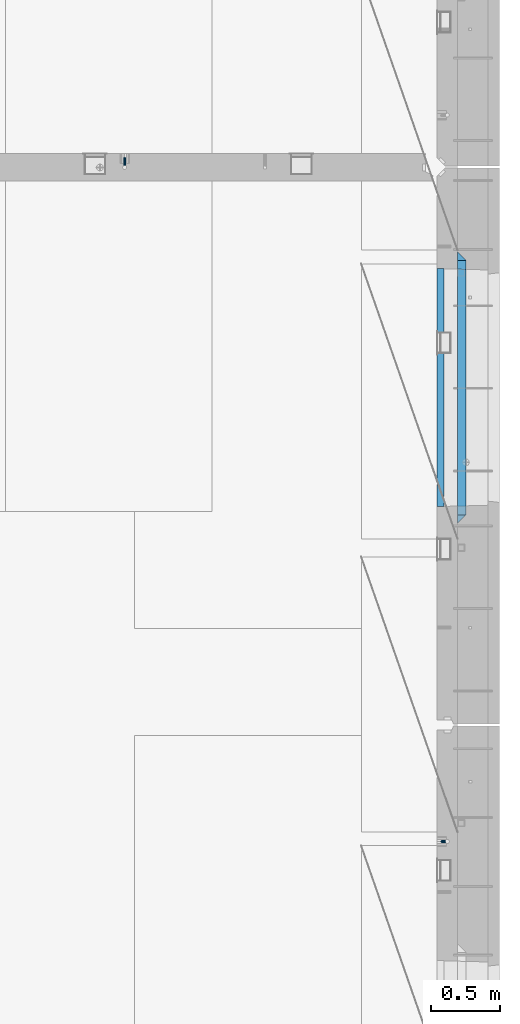
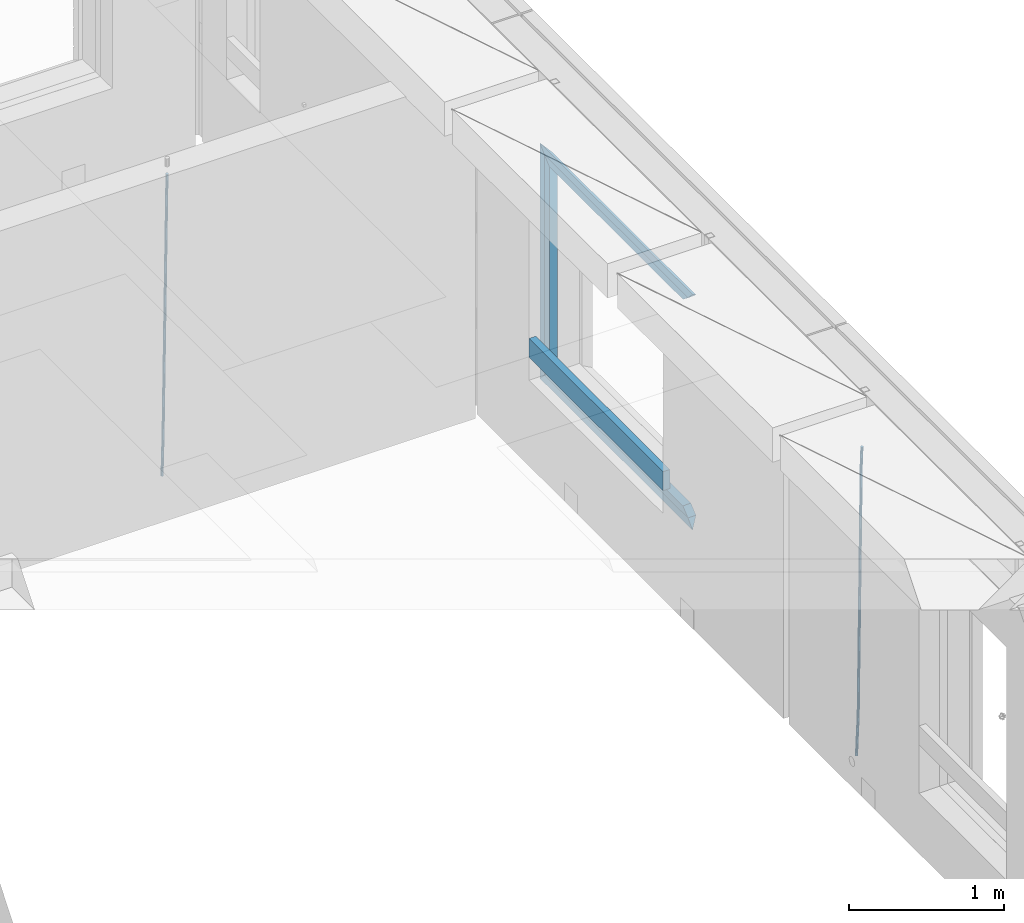
# One storey, part 125 of 334: 9 beams, 3 elements without a shape of their own.
"""IFC2X3 building model written with IfcOpenShell, lengths in millimetres."""

from ifc_helpers import new_model, si_unit, frame, origin_with_axes, place, context, subcontext, project, spatial, faceted_brep, material, type_object, element, aggregate, save


model = new_model("IFC2X3")

# Units and contexts
model_context = context("Model", 3, precision=1e-05, world=origin_with_axes())
body_context = subcontext(model_context, "Body", "Model", "MODEL_VIEW")
ifc_project = project(units=[si_unit("LENGTHUNIT", "METRE", prefix="MILLI"), si_unit("AREAUNIT", "SQUARE_METRE"), si_unit("VOLUMEUNIT", "CUBIC_METRE"), si_unit("MASSUNIT", "GRAM", prefix="KILO"), si_unit("TIMEUNIT", "SECOND"), si_unit("PLANEANGLEUNIT", "RADIAN"), si_unit("SOLIDANGLEUNIT", "STERADIAN"), si_unit("THERMODYNAMICTEMPERATUREUNIT", "DEGREE_CELSIUS"), si_unit("LUMINOUSINTENSITYUNIT", "LUMEN")], contexts=[model_context])

# Site, building, storey
site_placement = place(None, origin_with_axes())
site = spatial("IfcSite", under=ifc_project, at=site_placement, CompositionType="ELEMENT")
building_placement = place(site_placement, origin_with_axes())
building = spatial("IfcBuilding", under=site, at=building_placement, CompositionType="ELEMENT")
storey_placement = place(building_placement, origin_with_axes())
storey = spatial("IfcBuildingStorey", under=building, at=storey_placement, Name="3", CompositionType="ELEMENT", Elevation=0.0)

# Assembly, beam
assembly_1_placement = place(storey_placement, origin_with_axes())
assembly_1 = element("IfcElementAssembly", 1, at=assembly_1_placement, inside=storey, AssemblyPlace="NOTDEFINED", PredefinedType="REINFORCEMENT_UNIT")
ifc_material_1 = material()
beam_type_1 = type_object("IfcBeamType", Name="D20", PredefinedType="NOTDEFINED")
beam_1_placement = place(assembly_1_placement, frame((32639.9999999961, 17044.9997581385, 87990.0), z_axis=(0.00020576299992186, -0.999642804629538, -0.0267249099901004), x_axis=(-4.30000201928125e-08, -0.0267249099948059, 0.999642825806181)))
beam_1 = element("IfcBeam", 2, at=beam_1_placement, type_object=beam_type_1, material=ifc_material_1, Name="JM20", ObjectType="D20", context=body_context, shape_type="Brep", body=[
    faceted_brep([(0.0, -10.0, 0.0), (-4.19531716033816e-08, -7.07106781186667, -7.07106781187031), (60.4266690400545, -7.0710677960451, -7.07106780570757), (60.4266690441291, -9.99999998418934, 6.15546014159918e-09), (0.0, 0.0, -10.0), (60.426669036824, 1.58106558956206e-08, -9.99999999384454), (4.196772351861e-08, 7.07106781186303, -7.07106781186667), (60.4266690363438, 7.07106782768096, -7.07106780570757), (0.0, 10.0, 0.0), (60.4266690388904, 10.0000000158179, 6.15182216279209e-09), (4.196772351861e-08, 7.07106781185939, 7.07106781185939), (60.4266690429649, 7.07106782768096, 7.07106781802577), (0.0, 0.0, 10.0), (60.4266690461809, 1.58179318532348e-08, 10.0000000061555), (-4.19531716033816e-08, -7.07106781187031, 7.07106781185939), (60.4266690466611, -7.07106779605238, 7.07106781802213), (61.0378400410118, -7.07106779588503, -7.07106780564936), (60.991799419251, -9.99999998403655, 6.21366780251265e-09), (61.0569027789461, 1.5985278878361e-08, -9.99999999378269), (61.0378209396877, 7.07106782784831, -7.07106780564936), (60.9917724058905, 10.0000000159635, 6.21366780251265e-09), (60.9457317841297, 7.07106782781193, 7.0710678180767), (60.9266690461809, 1.59488990902901e-08, 10.0000000062028), (60.9457508854539, -7.07106779591413, 7.0710678180767), (61.6489592143771, -7.07106614513759, -7.06310863441468), (61.5568818710308, -9.9999984576425, 0.00735959856683621), (61.6870830769039, 1.71821739058942e-06, -9.99179257185824), (61.6489210170112, 7.07106947854481, -7.06310888312146), (61.556827851804, 10.0000015422847, 0.00735924683976918), (61.4647505084577, 7.07106922979438, 7.07782747982128), (61.4266266459163, 1.36643211590126e-06, 10.0065114172685), (61.464788705809, -7.07106639389531, 7.07782772852806), (176.543135720174, -7.07075579406956, -5.56673531796696), (176.451058376813, -9.99968810657447, 1.50373291501455), (176.581259582701, 0.000312069292704109, -8.49541925541052), (176.543097522794, 7.07137982961285, -5.56673556667374), (176.451004357587, 10.00031189336, 1.50373256329476), (176.35892701424, 7.07137958085514, 8.57420079627263), (176.320803151699, 0.000311717507429421, 11.5028847337162), (176.358965211621, -7.07075604281999, 8.57420104497578), (177.098753836006, -7.07075429323595, -5.55949898843028), (176.98362511232, -9.99968666800123, 1.510669025065), (177.146421932586, 0.000313595905026887, -8.48805862247536), (177.098706077581, 7.07138133041735, -5.55949936166144), (176.983557571715, 10.0003133318824, 1.51066849724157), (176.868428848029, 7.07138095712435, 8.58083651073321), (176.820760751449, 0.000313067976094317, 11.5093961447819), (176.868476606425, -7.07075466652896, 8.58083688396073), (177.654312950661, -7.07075204110879, -5.54863964998367), (177.516135294456, -9.99968450931192, 1.52107783331303), (177.711524267797, 0.000315886711177882, -8.47701274570863), (177.654255632195, 7.07138358250813, -5.54864021007961), (177.516054233929, 10.0003154905207, 1.5210770412159), (177.377876577739, 7.0713830223176, 8.59079452451624), (177.320665260588, 0.000315094497636892, 11.5191676202448), (177.377933896176, -7.07075260129932, 8.59079508461218), (299.499456785634, -7.07025810522464, -3.16697112782276), (299.361279129444, -9.99919057342777, 3.90274635547394), (299.556668102785, 0.000809822595329024, -6.09534422354773), (299.499399467197, 7.07187751838501, -3.1669716879187), (299.361198068917, 10.0008094264049, 3.90274556338045), (299.223020412712, 7.07187695819448, 10.9724630466735), (299.165809095575, 0.000809030381788034, 13.9008361423985), (299.223077731163, -7.07025866542244, 10.9724636067695), (300.03174732349, -7.07025594743027, -3.15656661289177), (299.971788958996, -9.99918809853989, 3.91467979818117), (300.056572611924, 0.000811849109595641, -6.08557274808481), (300.031722507032, 7.07187967631762, -3.15656653768019), (299.971753863239, 10.0008119014747, 3.91467990454839), (299.91179549876, 7.07187975035777, 10.9859263156177), (299.886970210311, 0.000811953817901667, 13.9149324508144), (299.911820315203, -7.0702558733974, 10.9859262404061), (300.564137759997, -7.07025623699155, -3.15794273276697), (300.582413367199, -9.99918843065097, 3.91310145956595), (300.556570941641, 0.000811577163403854, -6.0868651410201), (300.564145451674, 7.07187938674906, -3.15794274158179), (300.582424244858, 10.0008115693345, 3.91310144710224), (300.600699852032, 7.07187937566778, 10.9841456394352), (300.608266670402, 0.000811561512819026, 13.9130680476919), (300.600692160384, -7.07025624805829, 10.98414564825), (2294.16589219622, -7.0713405251372, -8.31099358700158), (2294.1841678034, -10.0002727187966, -1.23994939466866), (2294.15832537785, -0.000272710982244462, -11.2399159952547), (2294.16589988787, 7.07079509858886, -8.31099359582004), (2294.18417868105, 9.99972728118883, -1.23994940713601), (2294.20245428824, 7.07079508752213, 5.83109478519327), (2294.2100211066, -0.00027272663282929, 8.76001719345368), (2294.20244659658, -7.07134053620393, 5.83109479401173), (2294.7782683276, -7.07134085819416, -8.31257645345977), (2294.72126025338, -10.000273010919, -1.24133766827799), (2294.84007459224, -0.000273081772320438, -11.2416781768807), (2294.87047377572, 7.07079471537872, -8.31281477453012), (2294.85165844864, 9.9997269181622, -1.24167470516841), (2294.7946503744, 7.07079476544459, 5.82956408001337), (2294.73284410976, -0.000273010977252852, 8.75866580342336), (2294.7024449263, -7.07134080815013, 5.82980240107645), (2295.39054023061, -7.0793250091956, -8.30442771922026), (2295.25826128852, -10.0072756143927, -1.23419071494573), (2295.52170777075, -0.00916171800054144, -11.2326063125765), (2295.57492774284, 7.06160849139269, -8.30343918807193), (2295.51902460904, 9.99102432676591, -1.23279272078435), (2295.38674566693, 7.06307372157607, 5.83744428349019), (2295.25557812679, -0.0070895696117077, 8.76562287684646), (2295.20235815471, -7.07785977901949, 5.83645575234186), (2317.1947101649, -7.36365585014573, -8.01423575520312), (2317.06243122277, -10.2916064553428, -0.94399875092131), (2317.32587770502, -0.293492558957951, -10.9424143485521), (2317.37909767711, 6.77727765044983, -8.01324722405116), (2317.32319454331, 9.70669348581578, -0.942600756767206), (2317.1909156012, 6.77874288063322, 6.12763624751096), (2317.05974806109, -0.291420410569117, 9.0558148408636), (2317.00652808898, -7.36219061996962, 6.12664771636264), (2317.83015404257, -7.37194216843636, -8.00577862486898), (2317.72252095213, -10.300214160583, -0.935213608652703), (2317.90419832576, -0.301033978277701, -10.9347174723516), (2317.90127966482, 6.77046829039318, -8.00629749759901), (2317.82310777172, 9.70017451494641, -0.935947405505431), (2317.71547468127, 6.77190252279979, 6.13461761071085), (2317.64143039809, -0.29900566735887, 9.06355645819713), (2317.64434905903, -7.37050793602975, 6.13513648344451), (2318.46565174212, -7.3700661537805, -7.99751648408346), (2318.38266643914, -10.2982456018653, -0.926623872735945), (2318.48256818345, -0.299336209594912, -10.9272153854981), (2318.42350634121, 6.77200652527245, -7.99954269419686), (2318.32306384158, 9.70166538090416, -0.929489366557391), (2318.2400785386, 6.77348593281204, 6.14140324480104), (2318.22316209726, -0.297244011366274, 9.07110214621207), (2318.2822239395, -7.36858674623363, 6.1434294549108), (2418.48643733139, -7.07180401323421, -6.70013846199799), (2418.4034520284, -9.99998346132634, 0.370754149349523), (2418.5033537727, -0.00107406904135132, -9.62983736341266), (2418.44429193046, 7.07026866581873, -6.70216467211139), (2418.34384943081, 9.99992752145772, 0.367888655531715), (2418.26086412782, 7.0717480733656, 7.43878126688651), (2418.24394768651, 0.00101812917273492, 10.3684801682975), (2418.30300952874, -7.07032460568735, 7.44080747699627)], [[[0, 1, 2, 3]], [[1, 4, 5, 2]], [[4, 6, 7, 5]], [[6, 8, 9, 7]], [[8, 10, 11, 9]], [[10, 12, 13, 11]], [[12, 14, 15, 13]], [[14, 0, 3, 15]], [[14, 12, 10, 8, 6, 4, 1, 0]], [[3, 2, 16, 17]], [[2, 5, 18, 16]], [[5, 7, 19, 18]], [[7, 9, 20, 19]], [[9, 11, 21, 20]], [[11, 13, 22, 21]], [[13, 15, 23, 22]], [[15, 3, 17, 23]], [[17, 16, 24, 25]], [[16, 18, 26, 24]], [[18, 19, 27, 26]], [[19, 20, 28, 27]], [[20, 21, 29, 28]], [[21, 22, 30, 29]], [[22, 23, 31, 30]], [[23, 17, 25, 31]], [[25, 24, 32, 33]], [[24, 26, 34, 32]], [[26, 27, 35, 34]], [[27, 28, 36, 35]], [[28, 29, 37, 36]], [[29, 30, 38, 37]], [[30, 31, 39, 38]], [[31, 25, 33, 39]], [[33, 32, 40, 41]], [[32, 34, 42, 40]], [[34, 35, 43, 42]], [[35, 36, 44, 43]], [[36, 37, 45, 44]], [[37, 38, 46, 45]], [[38, 39, 47, 46]], [[39, 33, 41, 47]], [[41, 40, 48, 49]], [[40, 42, 50, 48]], [[42, 43, 51, 50]], [[43, 44, 52, 51]], [[44, 45, 53, 52]], [[45, 46, 54, 53]], [[46, 47, 55, 54]], [[47, 41, 49, 55]], [[49, 48, 56, 57]], [[48, 50, 58, 56]], [[50, 51, 59, 58]], [[51, 52, 60, 59]], [[52, 53, 61, 60]], [[53, 54, 62, 61]], [[54, 55, 63, 62]], [[55, 49, 57, 63]], [[57, 56, 64, 65]], [[56, 58, 66, 64]], [[58, 59, 67, 66]], [[59, 60, 68, 67]], [[60, 61, 69, 68]], [[61, 62, 70, 69]], [[62, 63, 71, 70]], [[63, 57, 65, 71]], [[65, 64, 72, 73]], [[64, 66, 74, 72]], [[66, 67, 75, 74]], [[67, 68, 76, 75]], [[68, 69, 77, 76]], [[69, 70, 78, 77]], [[70, 71, 79, 78]], [[71, 65, 73, 79]], [[73, 72, 80, 81]], [[72, 74, 82, 80]], [[74, 75, 83, 82]], [[75, 76, 84, 83]], [[76, 77, 85, 84]], [[77, 78, 86, 85]], [[78, 79, 87, 86]], [[79, 73, 81, 87]], [[81, 80, 88, 89]], [[80, 82, 90, 88]], [[82, 83, 91, 90]], [[83, 84, 92, 91]], [[84, 85, 93, 92]], [[85, 86, 94, 93]], [[86, 87, 95, 94]], [[87, 81, 89, 95]], [[89, 88, 96, 97]], [[88, 90, 98, 96]], [[90, 91, 99, 98]], [[91, 92, 100, 99]], [[92, 93, 101, 100]], [[93, 94, 102, 101]], [[94, 95, 103, 102]], [[95, 89, 97, 103]], [[97, 96, 104, 105]], [[96, 98, 106, 104]], [[98, 99, 107, 106]], [[99, 100, 108, 107]], [[100, 101, 109, 108]], [[101, 102, 110, 109]], [[102, 103, 111, 110]], [[103, 97, 105, 111]], [[105, 104, 112, 113]], [[104, 106, 114, 112]], [[106, 107, 115, 114]], [[107, 108, 116, 115]], [[108, 109, 117, 116]], [[109, 110, 118, 117]], [[110, 111, 119, 118]], [[111, 105, 113, 119]], [[113, 112, 120, 121]], [[112, 114, 122, 120]], [[114, 115, 123, 122]], [[115, 116, 124, 123]], [[116, 117, 125, 124]], [[117, 118, 126, 125]], [[118, 119, 127, 126]], [[119, 113, 121, 127]], [[121, 120, 128, 129]], [[120, 122, 130, 128]], [[122, 123, 131, 130]], [[123, 124, 132, 131]], [[124, 125, 133, 132]], [[125, 126, 134, 133]], [[126, 127, 135, 134]], [[127, 121, 129, 135]], [[130, 131, 132, 133, 134, 135, 129, 128]]]),
])
aggregate(assembly_1, [beam_1])

assembly_2_placement = place(storey_placement, origin_with_axes())
assembly_2 = element("IfcElementAssembly", 3, at=assembly_2_placement, inside=storey, AssemblyPlace="NOTDEFINED", PredefinedType="REINFORCEMENT_UNIT")
beam_2_placement = place(assembly_2_placement, frame((34944.9999977209, 12080.9402860984, 87990.0), z_axis=(0.999642804629538, 0.000205762999925497, -0.0267249099901003), x_axis=(0.0267249109941254, -4.30000210532798e-08, 0.999642825779465)))
beam_2 = element("IfcBeam", 4, at=beam_2_placement, type_object=beam_type_1, material=ifc_material_1, Name="JM20", ObjectType="D20", context=body_context, shape_type="Brep", body=[
    faceted_brep([(0.0, -10.0, 0.0), (-4.19531716033816e-08, -7.07106781186667, -7.07106781187031), (60.4266690400545, -7.0710677960451, -7.07106780570757), (60.4266690441291, -9.99999998418934, 6.15546014159918e-09), (0.0, 0.0, -10.0), (60.426669036824, 1.58106558956206e-08, -9.99999999384454), (4.196772351861e-08, 7.07106781186303, -7.07106781186667), (60.4266690363438, 7.07106782768096, -7.07106780570757), (0.0, 10.0, 0.0), (60.4266690388904, 10.0000000158179, 6.15182216279209e-09), (4.196772351861e-08, 7.07106781185939, 7.07106781185939), (60.4266690429649, 7.07106782768096, 7.07106781802577), (0.0, 0.0, 10.0), (60.4266690461809, 1.58179318532348e-08, 10.0000000061555), (-4.19531716033816e-08, -7.07106781187031, 7.07106781185939), (60.4266690466611, -7.07106779605238, 7.07106781802213), (61.0378400410118, -7.07106779588503, -7.07106780564936), (60.991799419251, -9.99999998403655, 6.21366780251265e-09), (61.0569027789461, 1.5985278878361e-08, -9.99999999378269), (61.0378209396877, 7.07106782784831, -7.07106780564936), (60.9917724058905, 10.0000000159635, 6.21366780251265e-09), (60.9457317841297, 7.07106782781193, 7.0710678180767), (60.9266690461809, 1.59488990902901e-08, 10.0000000062028), (60.9457508854539, -7.07106779591413, 7.0710678180767), (61.6489592143771, -7.07106614513759, -7.06310863441468), (61.5568818710308, -9.9999984576425, 0.00735959856683621), (61.6870830769039, 1.71821739058942e-06, -9.99179257185824), (61.6489210170112, 7.07106947854481, -7.06310888312146), (61.556827851804, 10.0000015422847, 0.00735924683976918), (61.4647505084577, 7.07106922979438, 7.07782747982128), (61.4266266459163, 1.36643211590126e-06, 10.0065114172685), (61.464788705809, -7.07106639389531, 7.07782772852806), (176.543135720174, -7.07075579406956, -5.56673531796696), (176.451058376813, -9.99968810657447, 1.50373291501455), (176.581259582701, 0.000312069292704109, -8.49541925541052), (176.543097522794, 7.07137982961285, -5.56673556667374), (176.451004357587, 10.00031189336, 1.50373256329476), (176.35892701424, 7.07137958085514, 8.57420079627263), (176.320803151699, 0.000311717507429421, 11.5028847337162), (176.358965211621, -7.07075604281999, 8.57420104497578), (177.098753836006, -7.07075429323595, -5.55949898843028), (176.98362511232, -9.99968666800123, 1.510669025065), (177.146421932586, 0.000313595905026887, -8.48805862247536), (177.098706077581, 7.07138133041735, -5.55949936166144), (176.983557571715, 10.0003133318824, 1.51066849724157), (176.868428848029, 7.07138095712435, 8.58083651073321), (176.820760751449, 0.000313067976094317, 11.5093961447819), (176.868476606425, -7.07075466652896, 8.58083688396073), (177.654312950661, -7.07075204110879, -5.54863964998367), (177.516135294456, -9.99968450931192, 1.52107783331303), (177.711524267797, 0.000315886711177882, -8.47701274570863), (177.654255632195, 7.07138358250813, -5.54864021007961), (177.516054233929, 10.0003154905207, 1.5210770412159), (177.377876577739, 7.0713830223176, 8.59079452451624), (177.320665260588, 0.000315094497636892, 11.5191676202448), (177.377933896176, -7.07075260129932, 8.59079508461218), (299.436796249574, -7.07025836271714, -3.1681962331204), (299.298618593355, -9.99919083092027, 3.90152125031091), (299.494007566798, 0.000809565110102994, -6.09656932889993), (299.436738931283, 7.07187726089978, -3.16819679320906), (299.298537533061, 10.0008091689197, 3.90152045822106), (299.160359876842, 7.07187670072017, 10.9712379416487), (299.103148559603, 0.000808772889286047, 13.8996110374392), (299.160417195119, -7.07025892290039, 10.9712385017483), (299.98743051647, -7.07025613056248, -3.15743315966392), (299.971788958996, -9.99918809853989, 3.91467979818117), (299.993912075952, 0.000811591617093654, -6.08679785393178), (299.987423933868, 7.07187949325817, -3.1574327280432), (299.971753863239, 10.0008119014747, 3.91467990454839), (299.95611230444, 7.07187992653053, 10.9867922621015), (299.949630744944, 0.000812204350950196, 13.9161569563694), (299.956118887014, -7.07025569729012, 10.9867918304735), (300.538107039494, -7.07025785017686, -3.16575821840888), (300.644985195438, -9.99919020432935, 3.90450175465594), (300.493854948218, 0.000810030429420294, -6.09435592770024), (300.538151196495, 7.071877773491, -3.16575855385963), (300.645047642858, 10.0008097955724, 3.90450128024895), (300.751925798773, 7.07187744142357, 10.9747612533101), (300.796177890064, 0.000809560813650023, 13.9033589625978), (300.751881641787, -7.07025818224065, 10.9747615887682), (2293.36490490142, -7.07648090940347, -33.2930642912361), (2293.47178305736, -10.0054132635523, -26.2228043181785), (2293.32065281013, -0.00541302880083094, -36.2216620005347), (2293.36494905842, 7.06565471425711, -33.2930646266868), (2293.47184550477, 9.99458673634581, -26.2228047925819), (2293.57872366071, 7.06565438219332, -19.1525448195243), (2293.62297575199, -0.00541349841296324, -16.2239471102366), (2293.57867950371, -7.0764812414709, -19.1525444840736), (2294.0658245362, -7.07648309818615, -33.3036607065333), (2294.05312277409, -10.0054150789219, -26.2315929392535), (2294.10928714235, -0.00541549149056664, -36.2335844756526), (2294.15805078732, 7.06565223761572, -33.3050546393533), (2294.18355038921, 9.99458451388637, -26.2335642579346), (2294.17084862708, 7.06565253314329, -19.1614964906439), (2294.12738602093, -0.00541507354500936, -16.2315727215355), (2294.07862237596, -7.07648280265857, -19.1601025578348), (2294.76670261032, -7.08562269121467, -33.294332712383), (2294.63442802057, -10.0129954178956, -26.2238563411993), (2294.89787471293, -0.0156988342423574, -36.2230891548279), (2294.95110548967, 7.05531064255774, -33.2944998654275), (2294.89521307347, 9.98530428734011, -26.2240927312887), (2294.76293848372, 7.0579315606592, -19.1536163601049), (2294.63176638114, -0.0119922963167483, -16.2248599176673), (2294.57853560438, -7.08300177311321, -19.1534492070678), (2316.52657204497, -7.36937582653991, -33.0047303660212), (2316.39429745522, -10.2967485532172, -25.9342539948302), (2316.65774414754, -0.299451969567599, -35.9334868084661), (2316.7109749243, 6.7715575072325, -33.0048975190657), (2316.65508250811, 9.70155115201487, -25.9344903849269), (2316.52280791836, 6.7741784253376, -18.8640140137468), (2316.39163581574, -0.295745431634714, -15.9352575713092), (2316.33840503903, -7.36675490843481, -18.863846860706), (2317.16202064224, -7.37766220584308, -32.9962731735213), (2317.05438744847, -10.3053562613532, -25.9254688497131), (2317.23607125619, -0.306993473008333, -35.925789846493), (2317.23316144495, 6.76474808850253, -32.9979477328052), (2317.15499573652, 9.6950321815566, -25.9278370341635), (2317.04736254275, 6.7673381260538, -18.8570327103698), (2316.97331192881, -0.303330606784584, -15.9275160373909), (2316.97622174003, -7.37507216829545, -18.8553581510787), (2317.79752306276, -7.37578610372293, -32.9880110666527), (2317.71453320107, -10.3033876998124, -25.9168792378296), (2317.81444760226, -0.305295583297266, -35.918287695793), (2317.75539265381, 6.76628640723357, -32.9911928173897), (2317.65495180529, 9.69652304524061, -25.9213789128698), (2317.5719619436, 6.76892144914746, -18.8502470840467), (2317.55503740412, -0.301569071270933, -15.9199704549137), (2317.61409235255, -7.3731510618054, -18.847065333317), (2417.8183084176, -7.07752398473531, -31.6906369377139), (2417.73531855589, -10.0051255808248, -24.6195051088798), (2417.83523295709, -0.007033464313281, -34.6209135668432), (2417.77617800863, 7.06454852621755, -31.6938186884508), (2417.67573716014, 9.99478516423187, -24.6240047839383), (2417.59274729842, 7.06718356813872, -17.5528729551006), (2417.57582275895, -0.00330695228694822, -14.6225963259749), (2417.6348777074, -7.07488894281778, -17.5496912043673)], [[[0, 1, 2, 3]], [[1, 4, 5, 2]], [[4, 6, 7, 5]], [[6, 8, 9, 7]], [[8, 10, 11, 9]], [[10, 12, 13, 11]], [[12, 14, 15, 13]], [[14, 0, 3, 15]], [[14, 12, 10, 8, 6, 4, 1, 0]], [[3, 2, 16, 17]], [[2, 5, 18, 16]], [[5, 7, 19, 18]], [[7, 9, 20, 19]], [[9, 11, 21, 20]], [[11, 13, 22, 21]], [[13, 15, 23, 22]], [[15, 3, 17, 23]], [[17, 16, 24, 25]], [[16, 18, 26, 24]], [[18, 19, 27, 26]], [[19, 20, 28, 27]], [[20, 21, 29, 28]], [[21, 22, 30, 29]], [[22, 23, 31, 30]], [[23, 17, 25, 31]], [[25, 24, 32, 33]], [[24, 26, 34, 32]], [[26, 27, 35, 34]], [[27, 28, 36, 35]], [[28, 29, 37, 36]], [[29, 30, 38, 37]], [[30, 31, 39, 38]], [[31, 25, 33, 39]], [[33, 32, 40, 41]], [[32, 34, 42, 40]], [[34, 35, 43, 42]], [[35, 36, 44, 43]], [[36, 37, 45, 44]], [[37, 38, 46, 45]], [[38, 39, 47, 46]], [[39, 33, 41, 47]], [[41, 40, 48, 49]], [[40, 42, 50, 48]], [[42, 43, 51, 50]], [[43, 44, 52, 51]], [[44, 45, 53, 52]], [[45, 46, 54, 53]], [[46, 47, 55, 54]], [[47, 41, 49, 55]], [[49, 48, 56, 57]], [[48, 50, 58, 56]], [[50, 51, 59, 58]], [[51, 52, 60, 59]], [[52, 53, 61, 60]], [[53, 54, 62, 61]], [[54, 55, 63, 62]], [[55, 49, 57, 63]], [[57, 56, 64, 65]], [[56, 58, 66, 64]], [[58, 59, 67, 66]], [[59, 60, 68, 67]], [[60, 61, 69, 68]], [[61, 62, 70, 69]], [[62, 63, 71, 70]], [[63, 57, 65, 71]], [[65, 64, 72, 73]], [[64, 66, 74, 72]], [[66, 67, 75, 74]], [[67, 68, 76, 75]], [[68, 69, 77, 76]], [[69, 70, 78, 77]], [[70, 71, 79, 78]], [[71, 65, 73, 79]], [[73, 72, 80, 81]], [[72, 74, 82, 80]], [[74, 75, 83, 82]], [[75, 76, 84, 83]], [[76, 77, 85, 84]], [[77, 78, 86, 85]], [[78, 79, 87, 86]], [[79, 73, 81, 87]], [[81, 80, 88, 89]], [[80, 82, 90, 88]], [[82, 83, 91, 90]], [[83, 84, 92, 91]], [[84, 85, 93, 92]], [[85, 86, 94, 93]], [[86, 87, 95, 94]], [[87, 81, 89, 95]], [[89, 88, 96, 97]], [[88, 90, 98, 96]], [[90, 91, 99, 98]], [[91, 92, 100, 99]], [[92, 93, 101, 100]], [[93, 94, 102, 101]], [[94, 95, 103, 102]], [[95, 89, 97, 103]], [[97, 96, 104, 105]], [[96, 98, 106, 104]], [[98, 99, 107, 106]], [[99, 100, 108, 107]], [[100, 101, 109, 108]], [[101, 102, 110, 109]], [[102, 103, 111, 110]], [[103, 97, 105, 111]], [[105, 104, 112, 113]], [[104, 106, 114, 112]], [[106, 107, 115, 114]], [[107, 108, 116, 115]], [[108, 109, 117, 116]], [[109, 110, 118, 117]], [[110, 111, 119, 118]], [[111, 105, 113, 119]], [[113, 112, 120, 121]], [[112, 114, 122, 120]], [[114, 115, 123, 122]], [[115, 116, 124, 123]], [[116, 117, 125, 124]], [[117, 118, 126, 125]], [[118, 119, 127, 126]], [[119, 113, 121, 127]], [[121, 120, 128, 129]], [[120, 122, 130, 128]], [[122, 123, 131, 130]], [[123, 124, 132, 131]], [[124, 125, 133, 132]], [[125, 126, 134, 133]], [[126, 127, 135, 134]], [[127, 121, 129, 135]], [[130, 131, 132, 133, 134, 135, 129, 128]]]),
])
aggregate(assembly_2, [beam_2])

# Assembly, beams
assembly_3_placement = place(storey_placement, origin_with_axes())
assembly_3 = element("IfcElementAssembly", 5, at=assembly_3_placement, inside=storey, AssemblyPlace="NOTDEFINED", PredefinedType="REINFORCEMENT_UNIT")
ifc_material_2 = material(Name="TIMBER/T24")
beam_type_2 = type_object("IfcBeamType", PredefinedType="NOTDEFINED")
beam_3_placement = place(assembly_3_placement, frame((34935.0002758707, 14515.0011884524, 88685.0), z_axis=(0.0, 0.0, 1.0), x_axis=(0.0, 1.0, 0.0)))
beam_3 = element("IfcBeam", 6, at=beam_3_placement, type_object=beam_type_2, material=ifc_material_2, context=body_context, shape_type="Brep", body=[
    faceted_brep([(-3.63797880709171e-12, 24.9999999999964, -75.0), (-3.63797880709171e-12, 24.9999999999964, 75.0), (1730.0, 25.0, 75.0), (1730.0, 25.0, -75.0), (0.0, -25.0000000000073, 75.0), (1730.0, -25.0, 75.0), (0.0, -25.0000000000073, -75.0), (1730.0, -25.0, -75.0)], [[[0, 1, 2, 3]], [[1, 4, 5, 2]], [[4, 6, 7, 5]], [[6, 0, 3, 7]], [[5, 7, 3, 2]], [[6, 4, 1, 0]]]),
])
ifc_material_3 = material(Name="CONCRETE/C25/30")
beam_type_3 = type_object("IfcBeamType", PredefinedType="NOTDEFINED")
beam_4_placement = place(assembly_3_placement, frame((35090.0, 14394.9995850056, 90145.0), z_axis=(0.0, 0.0, -1.0), x_axis=(0.0, 1.0, 0.0)))
beam_4 = element("IfcBeam", 7, at=beam_4_placement, type_object=beam_type_3, material=ifc_material_3, Name="SK", context=body_context, shape_type="Brep", body=[
    faceted_brep([(60.0000000000073, 30.0, 30.0), (0.0, -30.0, -30.0), (60.0000000000073, -30.0, 30.0), (1910.00076293945, 30.0, 30.0), (1970.00076293945, -30.0, -30.0), (1910.00076293945, -30.0, 30.0)], [[[0, 1, 2]], [[1, 0, 3, 4]], [[2, 1, 4, 5]], [[0, 2, 5, 3]], [[4, 3, 5]]]),
])
beam_5_placement = place(assembly_3_placement, frame((35090.0, 14454.9995850056, 90085.0), z_axis=(0.0, 0.0, -1.0), x_axis=(0.0, 1.0, 0.0)))
beam_5 = element("IfcBeam", 8, at=beam_5_placement, type_object=beam_type_3, material=ifc_material_3, Name="SK", context=body_context, shape_type="Brep", body=[
    faceted_brep([(1785.9467088854, -30.0, 24.0540540540533), (1784.32508726378, 30.0, 25.6756756756804), (65.6764386151262, 30.0, 25.6756756756804), (64.0548169935064, -30.0, 24.0540540540533), (65.6764386151262, 30.0, 26.294090229203), (64.0548169935064, -30.0, 24.9041288395529), (0.0, 30.0, -30.0), (0.0, -30.0, -30.0), (1850.00076293945, 30.0, -30.0), (1850.00076293945, -30.0, -30.0), (1785.9467088854, -30.0, 24.9034748914128), (1784.32508726378, 30.0, 26.2934362810774)], [[[0, 1, 2, 3]], [[3, 2, 4, 5]], [[5, 4, 6, 7]], [[7, 6, 8, 9]], [[0, 3, 5, 7, 9, 10]], [[1, 0, 10, 11]], [[6, 4, 2, 1, 11, 8]], [[9, 8, 11, 10]]]),
])
beam_6_placement = place(assembly_3_placement, frame((35090.0, 16335.0003479451, 90175.0), z_axis=(0.0, -1.0, 0.0), x_axis=(0.0, 0.0, -1.0)))
beam_6 = element("IfcBeam", 9, at=beam_6_placement, type_object=beam_type_3, material=ifc_material_3, Name="SK", context=body_context, shape_type="Brep", body=[
    faceted_brep([(60.0000000000073, 30.0, 30.0), (0.0, -30.0, -30.0), (60.0000000000073, -30.0, 30.0), (1795.00000000001, 30.0, 30.0), (1855.0, -30.0, -30.0), (1795.00000000001, -30.0, 30.0)], [[[0, 1, 2]], [[3, 4, 1, 0]], [[4, 5, 2, 1]], [[5, 3, 0, 2]], [[5, 4, 3]]]),
])
beam_7_placement = place(assembly_3_placement, frame((35090.0, 16305.0003479451, 88410.0), z_axis=(0.0, 0.0, 1.0), x_axis=(0.0, -1.0, 0.0)))
beam_7 = element("IfcBeam", 10, at=beam_7_placement, type_object=beam_type_3, material=ifc_material_3, Name="SK", context=body_context, shape_type="Brep", body=[
    faceted_brep([(1785.94594594595, -30.0, 24.0540540540533), (1784.32432432433, 30.0, 25.6756756756804), (65.6756756756768, 30.0, 25.6756756756804), (64.0540540540533, -30.0, 24.0540540540533), (1785.94594594595, -30.0, 24.9041288395238), (1784.32432432433, 30.0, 26.2940902291739), (1850.00076293945, -30.0, -30.0), (1850.00076293945, 30.0, -30.0), (0.0, 30.0, -30.0), (65.6756756756768, 30.0, 26.293436281092), (64.0540540540533, -30.0, 24.9034748914419), (0.0, -30.0, -30.0)], [[[0, 1, 2, 3]], [[1, 0, 4, 5]], [[4, 6, 7, 5]], [[2, 1, 5, 7, 8, 9]], [[3, 2, 9, 10]], [[6, 4, 0, 3, 10, 11]], [[11, 8, 7, 6]], [[11, 10, 9, 8]]]),
])
beam_8_placement = place(assembly_3_placement, frame((35090.0, 16365.0003479451, 88350.0), z_axis=(0.0, 0.0, 1.0), x_axis=(0.0, -1.0, 0.0)))
beam_8 = element("IfcBeam", 11, at=beam_8_placement, type_object=beam_type_3, material=ifc_material_3, Name="SK", context=body_context, shape_type="Brep", body=[
    faceted_brep([(1970.00076293945, -30.0, -30.0), (1910.00076293945, 30.0, 30.0), (1910.00076293945, -30.0, 30.0), (60.0000000000073, 30.0, 30.0), (60.0000000000073, -30.0, 30.0), (0.0, -30.0, -30.0)], [[[0, 1, 2]], [[3, 4, 2, 1]], [[4, 5, 0, 2]], [[5, 3, 1, 0]], [[3, 5, 4]]]),
])
beam_type_4 = type_object("IfcBeamType", PredefinedType="NOTDEFINED")
beam_9_placement = place(assembly_3_placement, frame((35090.0, 16270.0003479451, 90115.0), z_axis=(0.0, -1.0, 0.0), x_axis=(0.0, 0.0, -1.0)))
beam_9 = element("IfcBeam", 12, at=beam_9_placement, type_object=beam_type_4, material=ifc_material_3, Name="SK", context=body_context, shape_type="Brep", body=[
    faceted_brep([(0.0, -30.0, -35.0), (54.9034748914273, -30.0, 29.0540540540533), (56.2934362811066, 30.0, 30.6756756756768), (0.0, 30.0, -35.0), (1735.0, 30.0, -35.0), (1735.0, -30.0, -35.0), (1680.09652510857, -30.0, 29.0540540540533), (1678.70656371891, 30.0, 30.6756756756768)], [[[0, 1, 2, 3]], [[4, 5, 0, 3]], [[1, 0, 5, 6]], [[2, 1, 6, 7]], [[3, 2, 7, 4]], [[5, 4, 7, 6]]]),
])
aggregate(assembly_3, [beam_3, beam_4, beam_5, beam_6, beam_9, beam_7, beam_8])

save(model, "model.ifc")
